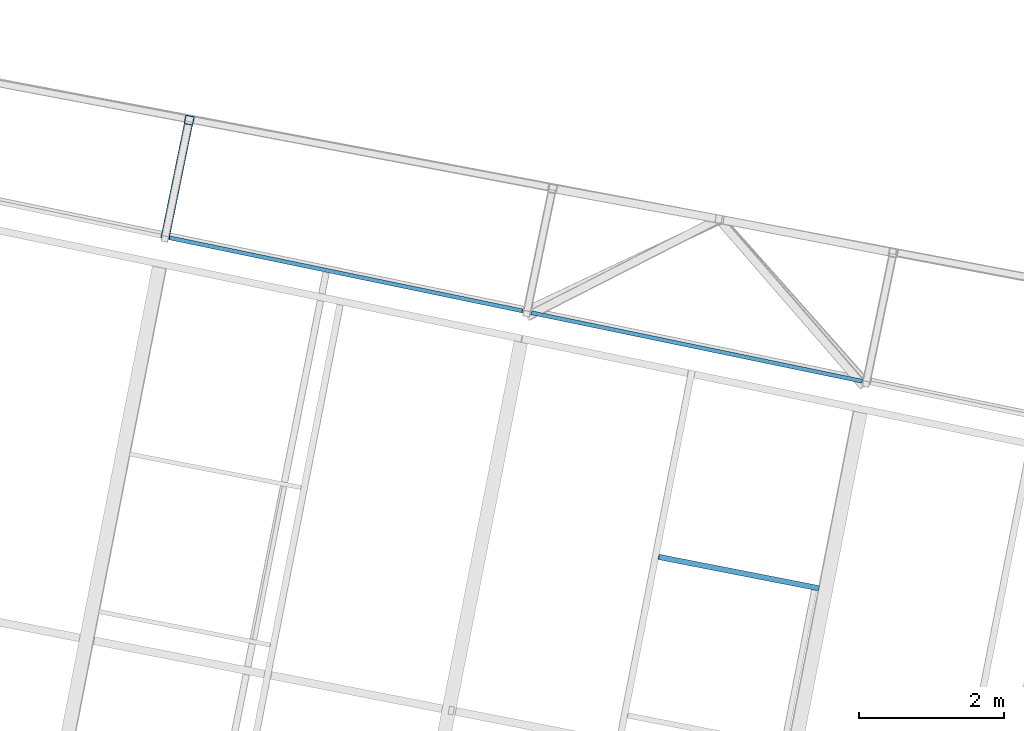
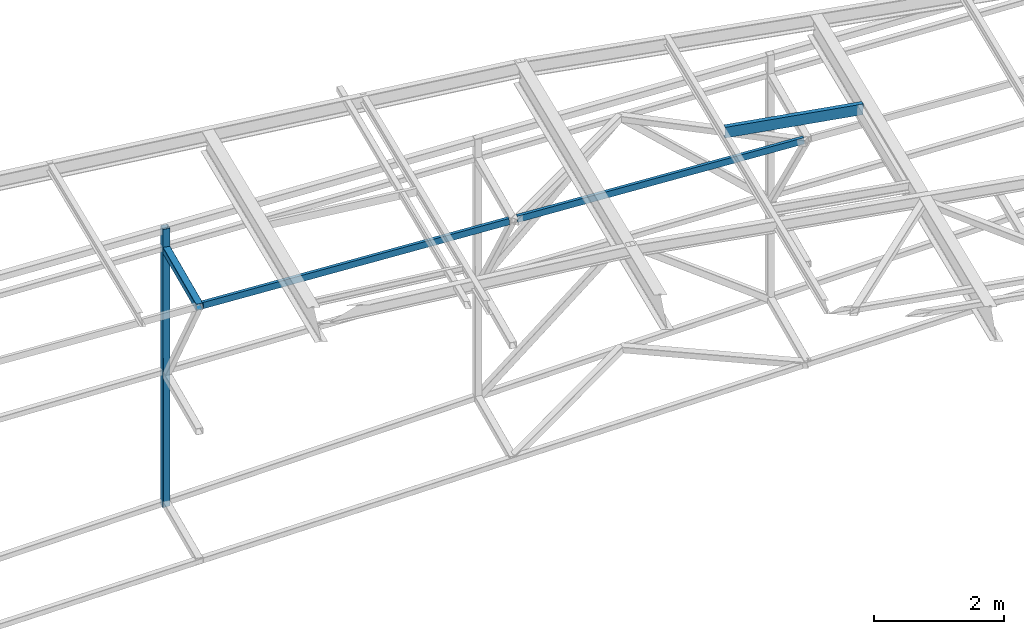
# One storey, part 94 of 215: 5 beams, 5 elements without a shape of their own.
"""IFC2X3 building model written with IfcOpenShell, lengths in millimetres."""

import ifcopenshell
import ifcopenshell.guid

model = None  # the IFC model being written
_history = None  # IfcOwnerHistory: only IFC2X3 demands one
_inside = {}  # id of a spatial element -> (the spatial element, [elements in it])
_under = {}  # id of a project, library or spatial element -> (it, [spatial elements below it])
_declared = {}  # id of a project -> (the project, [libraries it declares])
_typed = {}  # id of a type object -> (the type object, [elements of that type])
_made_of = {}  # id of a material, layer set ... -> (it, [elements and type objects made of it])


def new_model(schema):
    """Start an empty IFC model of exactly this schema.

    Asked for "IFC4X3", IfcOpenShell would pick the latest addendum, in which some entities
    have other attributes; the version numbers below select the first issue.
    IFC2X3 requires an IfcOwnerHistory on every rooted entity: one is made here for all.
    """
    global model, _history
    if schema == "IFC4X3":
        model = ifcopenshell.file(schema_version=(4, 3, 0, 0))
    else:
        model = ifcopenshell.file(schema=schema)
    _inside.clear()
    _under.clear()
    _declared.clear()
    _typed.clear()
    _made_of.clear()
    _history = None
    if model.schema == "IFC2X3":
        org = make("IfcOrganization", Name="unknown")
        user = make(
            "IfcPersonAndOrganization",
            ThePerson=make("IfcPerson", FamilyName="unknown"),
            TheOrganization=org,
        )
        app = make(
            "IfcApplication",
            ApplicationDeveloper=org,
            Version="unknown",
            ApplicationFullName="unknown",
            ApplicationIdentifier="unknown",
        )
        _history = make(
            "IfcOwnerHistory",
            OwningUser=user,
            OwningApplication=app,
            ChangeAction="ADDED",
            CreationDate=0,
        )
    return model


def make(cls, **values):
    """One entity of the class cls with the attributes given. An attribute that is None is left unset."""
    return model.create_entity(
        cls, **{name: value for name, value in values.items() if value is not None}
    )


def rooted(cls, **values):
    """An entity with a GlobalId (a new one), such as an element, a storey or a relation."""
    return make(cls, GlobalId=ifcopenshell.guid.new(), OwnerHistory=_history, **values)


def si_unit(unit_type, name, prefix=None):
    """IfcSIUnit, for example si_unit("LENGTHUNIT", "METRE", prefix="MILLI")."""
    return make("IfcSIUnit", UnitType=unit_type, Prefix=prefix, Name=name)


def assignment(units):
    """IfcUnitAssignment: the units of a project."""
    return None if units is None else make("IfcUnitAssignment", Units=units)


def point(xyz):
    """IfcCartesianPoint."""
    return None if xyz is None else make("IfcCartesianPoint", Coordinates=xyz)


def direction(xyz):
    """IfcDirection."""
    return None if xyz is None else make("IfcDirection", DirectionRatios=xyz)


def frame(location, z_axis=None, x_axis=None):
    """IfcAxis2Placement3D, a coordinate frame: its origin and axes. An axis left out is left unset."""
    return make(
        "IfcAxis2Placement3D",
        Location=point(location),
        Axis=direction(z_axis),
        RefDirection=direction(x_axis),
    )


def frame_2d(location, x_axis=None):
    """IfcAxis2Placement2D, a coordinate frame in the plane: its origin and x axis."""
    return make(
        "IfcAxis2Placement2D", Location=point(location), RefDirection=direction(x_axis)
    )


def origin_with_axes():
    """The frame at (0, 0, 0) with the z axis (0, 0, 1) and the x axis (1, 0, 0) written out."""
    return frame((0.0, 0.0, 0.0), z_axis=(0.0, 0.0, 1.0), x_axis=(1.0, 0.0, 0.0))


def origin_2d_with_axis():
    """The frame at (0, 0) in the plane with the x axis (1, 0) written out."""
    return frame_2d((0.0, 0.0), x_axis=(1.0, 0.0))


def place(relative_to, where):
    """IfcLocalPlacement: puts the frame where relative to a parent placement (None: the world)."""
    return make(
        "IfcLocalPlacement", PlacementRelTo=relative_to, RelativePlacement=where
    )


def context(
    kind, dimensions, precision=None, world=None, true_north=None, identifier=None
):
    """IfcGeometricRepresentationContext, for example the 3D "Model" context."""
    return make(
        "IfcGeometricRepresentationContext",
        ContextIdentifier=identifier,
        ContextType=kind,
        CoordinateSpaceDimension=dimensions,
        Precision=precision,
        WorldCoordinateSystem=world,
        TrueNorth=true_north,
    )


def subcontext(parent, identifier, kind, view, scale=None):
    """IfcGeometricRepresentationSubContext, for example "Body" below "Model"."""
    return make(
        "IfcGeometricRepresentationSubContext",
        ContextIdentifier=identifier,
        ContextType=kind,
        ParentContext=parent,
        TargetScale=scale,
        TargetView=view,
    )


def project(units=None, contexts=None):
    """IfcProject with its units and contexts."""
    return rooted(
        "IfcProject",
        Name="project",
        RepresentationContexts=contexts,
        UnitsInContext=assignment(units),
    )


def spatial(cls, under=None, at=None, **own):
    """A site, building, storey or space (cls), placed at a placement, below another one or the project."""
    s = rooted(cls, ObjectPlacement=at, **own)
    if under is not None:
        _under.setdefault(under.id(), (under, []))[1].append(s)
    return s


def profile(cls, at=None, kind="AREA", **sizes):
    """A parametric profile (cls). Its sizes go by their IFC names, for example OverallWidth=200.0."""
    return make(cls, ProfileType=kind, Position=at, **sizes)


def hollow_rectangle(**sizes):
    """IfcRectangleHollowProfileDef."""
    return profile("IfcRectangleHollowProfileDef", **sizes)


def u_section(**sizes):
    """IfcUShapeProfileDef."""
    return profile("IfcUShapeProfileDef", **sizes)


def extrude(swept, where, along, depth):
    """IfcExtrudedAreaSolid: the profile swept, set in the frame where, extruded along a direction by depth."""
    return make(
        "IfcExtrudedAreaSolid",
        SweptArea=swept,
        Position=where,
        ExtrudedDirection=direction(along),
        Depth=depth,
    )


def clip(a, b, op="DIFFERENCE"):
    """IfcBooleanClippingResult: the solid a cut by the half space b."""
    return make(
        "IfcBooleanClippingResult", Operator=op, FirstOperand=a, SecondOperand=b
    )


def halfspace(plane, agree):
    """IfcHalfSpaceSolid: all space on one side of the plane z = 0 of the frame plane."""
    return make(
        "IfcHalfSpaceSolid",
        BaseSurface=make("IfcPlane", Position=plane),
        AgreementFlag=agree,
    )


def shape(context_of_items, identifier, shape_type, items):
    """IfcShapeRepresentation: the items that make up one representation, for example the "Body"."""
    return make(
        "IfcShapeRepresentation",
        ContextOfItems=context_of_items,
        RepresentationIdentifier=identifier,
        RepresentationType=shape_type,
        Items=items,
    )


def material(Name=None, Category=None):
    """IfcMaterial."""
    return make("IfcMaterial", Name=Name, Category=Category)


def made_of(thing, what):
    """Note that an element or type object is made of a material, layer set ...; save() writes the relation."""
    if what is not None:
        _made_of.setdefault(what.id(), (what, []))[1].append(thing)
    return thing


def type_object(cls, material=None, **own):
    """A type object (cls), such as IfcWallType, which elements share."""
    return made_of(rooted(cls, **own), material)


def element(
    cls,
    number,
    at=None,
    inside=None,
    cuts=None,
    type_object=None,
    material=None,
    context=None,
    identifier="Body",
    shape_type=None,
    held_by="IfcProductDefinitionShape",
    body=None,
    shapes=None,
    **own,
):
    """One element of the class cls, such as IfcWall. Its Tag is "e" and its number.

    at: its placement. inside: the storey or other place that contains it. cuts: it is an
    opening in that element (IfcRelVoidsElement). A single representation is given by context,
    identifier, shape_type and body (its items); several are given by shapes. held_by: the class
    of the entity that holds the representations. save() writes the other relations.
    """
    e = rooted(cls, Tag="e%d" % number, ObjectPlacement=at, **own)
    if body is not None:
        shapes = [shape(context, identifier, shape_type, body)]
    if shapes is not None:
        e.Representation = make(held_by, Representations=shapes)
    if inside is not None:
        _inside.setdefault(inside.id(), (inside, []))[1].append(e)
    if cuts is not None:
        rooted(
            "IfcRelVoidsElement", RelatingBuildingElement=cuts, RelatedOpeningElement=e
        )
    if type_object is not None:
        _typed.setdefault(type_object.id(), (type_object, []))[1].append(e)
    return made_of(e, material)


def aggregate(whole, parts):
    """IfcRelAggregates: a whole, such as a stair, and the parts it consists of."""
    return rooted("IfcRelAggregates", RelatingObject=whole, RelatedObjects=parts)


def save(model, path):
    """Write the relations noted so far, then the file.

    IfcRelAggregates (storeys below a building ...), IfcRelContainedInSpatialStructure (elements
    in a storey), IfcRelDefinesByType, IfcRelAssociatesMaterial and IfcRelDeclares: one each for
    every whole, place, type object, material and project.
    """
    for whole, parts in _under.values():
        aggregate(whole, parts)
    for where, things in _inside.values():
        rooted(
            "IfcRelContainedInSpatialStructure",
            RelatedElements=things,
            RelatingStructure=where,
        )
    for kind, things in _typed.values():
        rooted("IfcRelDefinesByType", RelatedObjects=things, RelatingType=kind)
    for what, things in _made_of.values():
        rooted("IfcRelAssociatesMaterial", RelatedObjects=things, RelatingMaterial=what)
    for by, libraries in _declared.values():
        rooted("IfcRelDeclares", RelatingContext=by, RelatedDefinitions=libraries)
    model.write(path)


model = new_model("IFC2X3")

# Units and contexts
model_context = context("Model", 3, precision=1e-05, world=origin_with_axes())
body_context = subcontext(model_context, "Body", "Model", "MODEL_VIEW")
ifc_project = project(units=[si_unit("LENGTHUNIT", "METRE", prefix="MILLI"), si_unit("AREAUNIT", "SQUARE_METRE"), si_unit("VOLUMEUNIT", "CUBIC_METRE"), si_unit("MASSUNIT", "GRAM", prefix="KILO"), si_unit("TIMEUNIT", "SECOND"), si_unit("PLANEANGLEUNIT", "RADIAN"), si_unit("SOLIDANGLEUNIT", "STERADIAN"), si_unit("THERMODYNAMICTEMPERATUREUNIT", "DEGREE_CELSIUS"), si_unit("LUMINOUSINTENSITYUNIT", "LUMEN")], contexts=[model_context])

# Site, building, storey
site_placement = place(None, origin_with_axes())
site = spatial("IfcSite", under=ifc_project, at=site_placement, CompositionType="ELEMENT")
building_placement = place(site_placement, origin_with_axes())
building = spatial("IfcBuilding", under=site, at=building_placement, Name="Undefined", CompositionType="ELEMENT")
storey_placement = place(building_placement, origin_with_axes())
storey = spatial("IfcBuildingStorey", under=building, at=storey_placement, Name="Undefined", CompositionType="ELEMENT", Elevation=0.0)

# Assembly, beam
assembly_1_placement = place(storey_placement, origin_with_axes())
assembly_1 = element("IfcElementAssembly", 1, at=assembly_1_placement, inside=storey, Name="Steel Assembly", AssemblyPlace="NOTDEFINED", PredefinedType="RIGID_FRAME")
ifc_material_1 = material(Name="STEEL/S275JR")
beam_type_1 = type_object("IfcBeamType", PredefinedType="NOTDEFINED")
beam_1_placement = place(assembly_1_placement, frame((70875.1553118734, 62669.0456668299, 9570.34870532724), z_axis=(-0.201058572041247, -0.979579221200988, -1.00000033874093e-09), x_axis=(0.0, 0.0, -1.0)))
beam_1 = element("IfcBeam", 2, at=beam_1_placement, type_object=beam_type_1, material=ifc_material_1, Name="MONTANT", context=body_context, shape_type="Clipping", body=[
    clip(extrude(hollow_rectangle(XDim=120.0, YDim=120.0, WallThickness=5.0, InnerFilletRadius=5.0, OuterFilletRadius=10.0, at=origin_2d_with_axis()), frame((5234.13581073541, 7.27595761418343e-12, 1.45519152283669e-11), z_axis=(-1.0, 0.0, 0.0), x_axis=(-6.93889390390723e-18, -1.0, -3.46944695195361e-18)), (0.0, 0.0, 1.0), 5234.1), halfspace(frame((5211.70176572321, 82.2931683953066, -60.6289082949661), z_axis=(0.988050902406614, 0.154123414224719, -0.00117789693607931), x_axis=(0.0, -0.007642341407296, -0.999970796882496)), False)),
])
aggregate(assembly_1, [beam_1])

assembly_2_placement = place(storey_placement, origin_with_axes())
assembly_2 = element("IfcElementAssembly", 3, at=assembly_2_placement, inside=storey, Name="Steel Assembly", AssemblyPlace="NOTDEFINED", PredefinedType="RIGID_FRAME")
beam_2_placement = place(assembly_2_placement, frame((70863.0917957259, 62610.2709132703, 9172.72531547796), z_axis=(0.97957922139794, -0.201058571081677, 0.0), x_axis=(-0.201058572041247, -0.979579221200988, -1.00000033874093e-09)))
beam_2 = element("IfcBeam", 4, at=beam_2_placement, type_object=beam_type_1, material=ifc_material_1, context=body_context, shape_type="SweptSolid", body=[
    extrude(hollow_rectangle(XDim=120.0, YDim=120.0, WallThickness=5.0, InnerFilletRadius=5.0, OuterFilletRadius=10.0, at=origin_2d_with_axis()), frame((1609.80539167399, 0.0, 4.46810752750545e-14), z_axis=(-1.0, 0.0, 0.0), x_axis=(-6.93889390390723e-18, -1.0, -3.46944695195361e-18)), (0.0, 0.0, 1.0), 1609.8),
])
aggregate(assembly_2, [beam_2])

assembly_3_placement = place(storey_placement, origin_with_axes())
assembly_3 = element("IfcElementAssembly", 5, at=assembly_3_placement, inside=storey, Name="Steel Assembly", AssemblyPlace="NOTDEFINED", PredefinedType="RIGID_FRAME")
ifc_material_2 = material(Name="STEEL/S235JR")
beam_type_2 = type_object("IfcBeamType", Name="UPN200", PredefinedType="NOTDEFINED")
beam_3_placement = place(assembly_3_placement, frame((79546.9121598481, 56222.7213873924, 12674.7328528329), z_axis=(0.0304080349965938, -0.00594450399933318, 0.999519891888024), x_axis=(-0.980947274706054, 0.19178753394253, 0.030983641990716)))
beam_3 = element("IfcBeam", 6, at=beam_3_placement, type_object=beam_type_2, material=ifc_material_2, ObjectType="UPN200", context=body_context, shape_type="SweptSolid", body=[
    extrude(u_section(Depth=200.0, FlangeWidth=75.0, WebThickness=8.5, FlangeThickness=11.5, FilletRadius=11.5, EdgeRadius=6.0, FlangeSlope=0.0798299857122373, at=origin_2d_with_axis()), frame((2249.04686463703, -3.60705473231594e-12, 7.80294878931578e-15), z_axis=(-1.0, 0.0, 0.0), x_axis=(-6.93889390390723e-18, -1.0, -3.46944695195361e-18)), (0.0, 0.0, 1.0), 2249.0),
])
aggregate(assembly_3, [beam_3])

assembly_4_placement = place(storey_placement, origin_with_axes())
assembly_4 = element("IfcElementAssembly", 7, at=assembly_4_placement, inside=storey, Name="Steel Assembly", AssemblyPlace="NOTDEFINED", PredefinedType="RIGID_FRAME")
beam_type_3 = type_object("IfcBeamType", Name="UPN120", PredefinedType="NOTDEFINED")
beam_4_placement = place(assembly_4_placement, frame((70594.7435177413, 61050.4730623407, 9181.01818950301), z_axis=(0.0955015649822119, -0.0197745719963192, -0.995232845814642), x_axis=(0.974560481902769, -0.201792676979867, 0.0975273429902698)))
beam_4 = element("IfcBeam", 8, at=beam_4_placement, type_object=beam_type_3, material=ifc_material_1, ObjectType="UPN120", context=body_context, shape_type="SweptSolid", body=[
    extrude(u_section(Depth=120.0, FlangeWidth=55.0, WebThickness=7.0, FlangeThickness=9.0, FilletRadius=9.0, EdgeRadius=4.5, FlangeSlope=0.0798299857122373, at=origin_2d_with_axis()), frame((4998.45807130913, 1.43865529837918e-11, -1.29487451217951e-12), z_axis=(-1.0, 0.0, 0.0), x_axis=(-6.93889390390723e-18, -1.0, -3.46944695195361e-18)), (0.0, 0.0, 1.0), 4998.5),
])
aggregate(assembly_4, [beam_4])

assembly_5_placement = place(storey_placement, origin_with_axes())
assembly_5 = element("IfcElementAssembly", 9, at=assembly_5_placement, inside=storey, Name="Steel Assembly", AssemblyPlace="NOTDEFINED", PredefinedType="RIGID_FRAME")
beam_5_placement = place(assembly_5_placement, frame((75595.2943528026, 60014.9786930343, 9681.44075346529), z_axis=(0.0955021749987701, -0.0197716169997436, -0.995232845987169), x_axis=(0.974566724502395, -0.201762526896981, 0.0975273409502033)))
beam_5 = element("IfcBeam", 10, at=beam_5_placement, type_object=beam_type_3, material=ifc_material_1, ObjectType="UPN120", context=body_context, shape_type="SweptSolid", body=[
    extrude(u_section(Depth=120.0, FlangeWidth=55.0, WebThickness=7.0, FlangeThickness=9.0, FilletRadius=9.0, EdgeRadius=4.5, FlangeSlope=0.0798299857122373, at=origin_2d_with_axis()), frame((4672.72229202776, -7.97587724207366e-14, -2.72848410531878e-12), z_axis=(-1.0, 0.0, 0.0), x_axis=(-6.93889390390723e-18, -1.0, -3.46944695195361e-18)), (0.0, 0.0, 1.0), 4672.7),
])
aggregate(assembly_5, [beam_5])

save(model, "model.ifc")
